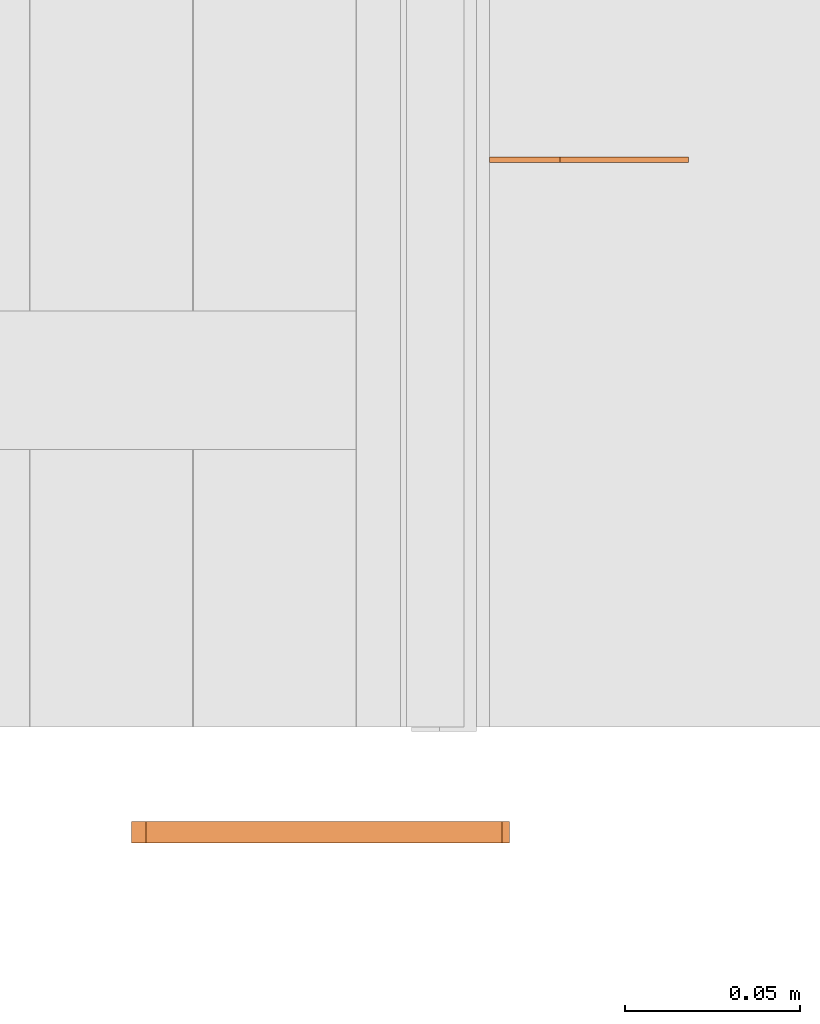
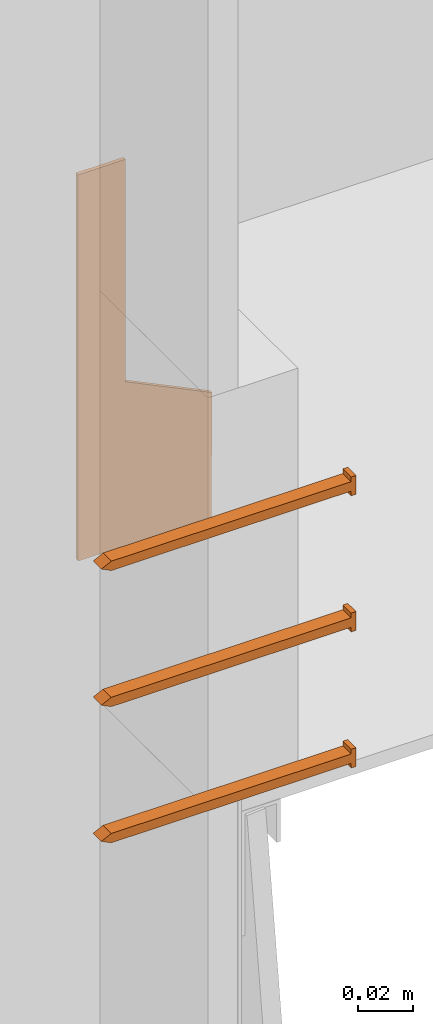
# One storey, part 12 of 22: 4 proxies.
"""IFC2X3 building model written with IfcOpenShell, lengths in feet."""

import ifcopenshell
import ifcopenshell.guid

model = None  # the IFC model being written
_history = None  # IfcOwnerHistory: only IFC2X3 demands one
_inside = {}  # id of a spatial element -> (the spatial element, [elements in it])
_under = {}  # id of a project, library or spatial element -> (it, [spatial elements below it])
_declared = {}  # id of a project -> (the project, [libraries it declares])
_typed = {}  # id of a type object -> (the type object, [elements of that type])
_made_of = {}  # id of a material, layer set ... -> (it, [elements and type objects made of it])


def new_model(schema):
    """Start an empty IFC model of exactly this schema.

    Asked for "IFC4X3", IfcOpenShell would pick the latest addendum, in which some entities
    have other attributes; the version numbers below select the first issue.
    IFC2X3 requires an IfcOwnerHistory on every rooted entity: one is made here for all.
    """
    global model, _history
    if schema == "IFC4X3":
        model = ifcopenshell.file(schema_version=(4, 3, 0, 0))
    else:
        model = ifcopenshell.file(schema=schema)
    _inside.clear()
    _under.clear()
    _declared.clear()
    _typed.clear()
    _made_of.clear()
    _history = None
    if model.schema == "IFC2X3":
        org = make("IfcOrganization", Name="unknown")
        user = make(
            "IfcPersonAndOrganization",
            ThePerson=make("IfcPerson", FamilyName="unknown"),
            TheOrganization=org,
        )
        app = make(
            "IfcApplication",
            ApplicationDeveloper=org,
            Version="unknown",
            ApplicationFullName="unknown",
            ApplicationIdentifier="unknown",
        )
        _history = make(
            "IfcOwnerHistory",
            OwningUser=user,
            OwningApplication=app,
            ChangeAction="ADDED",
            CreationDate=0,
        )
    return model


def make(cls, **values):
    """One entity of the class cls with the attributes given. An attribute that is None is left unset."""
    return model.create_entity(
        cls, **{name: value for name, value in values.items() if value is not None}
    )


def entity(cls, *values):
    """Any entity or typed value of the class cls, its attributes in the order of the schema. None: left unset."""
    e = model.create_entity(cls)
    for i, value in enumerate(values):
        if value is not None:
            e[i] = value
    return e


def rooted(cls, **values):
    """An entity with a GlobalId (a new one), such as an element, a storey or a relation."""
    return make(cls, GlobalId=ifcopenshell.guid.new(), OwnerHistory=_history, **values)


def si_unit(unit_type, name, prefix=None):
    """IfcSIUnit, for example si_unit("LENGTHUNIT", "METRE", prefix="MILLI")."""
    return make("IfcSIUnit", UnitType=unit_type, Prefix=prefix, Name=name)


def converted_unit(unit_type, name, factor, base, dimensions=None, offset=None):
    """IfcConversionBasedUnit, such as the inch: factor (a typed value) times the base unit."""
    return make(
        "IfcConversionBasedUnit"
        if offset is None
        else "IfcConversionBasedUnitWithOffset",
        ConversionOffset=offset,
        Dimensions=None
        if dimensions is None
        else entity("IfcDimensionalExponents", *dimensions),
        UnitType=unit_type,
        Name=name,
        ConversionFactor=make(
            "IfcMeasureWithUnit", ValueComponent=factor, UnitComponent=base
        ),
    )


def assignment(units):
    """IfcUnitAssignment: the units of a project."""
    return None if units is None else make("IfcUnitAssignment", Units=units)


def point(xyz):
    """IfcCartesianPoint."""
    return None if xyz is None else make("IfcCartesianPoint", Coordinates=xyz)


def direction(xyz):
    """IfcDirection."""
    return None if xyz is None else make("IfcDirection", DirectionRatios=xyz)


def frame(location, z_axis=None, x_axis=None):
    """IfcAxis2Placement3D, a coordinate frame: its origin and axes. An axis left out is left unset."""
    return make(
        "IfcAxis2Placement3D",
        Location=point(location),
        Axis=direction(z_axis),
        RefDirection=direction(x_axis),
    )


def frame_2d(location, x_axis=None):
    """IfcAxis2Placement2D, a coordinate frame in the plane: its origin and x axis."""
    return make(
        "IfcAxis2Placement2D", Location=point(location), RefDirection=direction(x_axis)
    )


def origin_with_axes():
    """The frame at (0, 0, 0) with the z axis (0, 0, 1) and the x axis (1, 0, 0) written out."""
    return frame((0.0, 0.0, 0.0), z_axis=(0.0, 0.0, 1.0), x_axis=(1.0, 0.0, 0.0))


def place(relative_to, where):
    """IfcLocalPlacement: puts the frame where relative to a parent placement (None: the world)."""
    return make(
        "IfcLocalPlacement", PlacementRelTo=relative_to, RelativePlacement=where
    )


def context(
    kind, dimensions, precision=None, world=None, true_north=None, identifier=None
):
    """IfcGeometricRepresentationContext, for example the 3D "Model" context."""
    return make(
        "IfcGeometricRepresentationContext",
        ContextIdentifier=identifier,
        ContextType=kind,
        CoordinateSpaceDimension=dimensions,
        Precision=precision,
        WorldCoordinateSystem=world,
        TrueNorth=true_north,
    )


def subcontext(parent, identifier, kind, view, scale=None):
    """IfcGeometricRepresentationSubContext, for example "Body" below "Model"."""
    return make(
        "IfcGeometricRepresentationSubContext",
        ContextIdentifier=identifier,
        ContextType=kind,
        ParentContext=parent,
        TargetScale=scale,
        TargetView=view,
    )


def project(units=None, contexts=None):
    """IfcProject with its units and contexts."""
    return rooted(
        "IfcProject",
        Name="project",
        RepresentationContexts=contexts,
        UnitsInContext=assignment(units),
    )


def spatial(cls, under=None, at=None, **own):
    """A site, building, storey or space (cls), placed at a placement, below another one or the project."""
    s = rooted(cls, ObjectPlacement=at, **own)
    if under is not None:
        _under.setdefault(under.id(), (under, []))[1].append(s)
    return s


def polyline(points):
    """IfcPolyline through the points."""
    return make("IfcPolyline", Points=[point(p) for p in points])


def outline(outer, holes=None, kind="AREA"):
    """IfcArbitraryClosedProfileDef: a profile drawn as a closed curve; with holes, ...WithVoids."""
    if holes is None:
        return make("IfcArbitraryClosedProfileDef", ProfileType=kind, OuterCurve=outer)
    return make(
        "IfcArbitraryProfileDefWithVoids",
        ProfileType=kind,
        OuterCurve=outer,
        InnerCurves=holes,
    )


def extrude(swept, where, along, depth):
    """IfcExtrudedAreaSolid: the profile swept, set in the frame where, extruded along a direction by depth."""
    return make(
        "IfcExtrudedAreaSolid",
        SweptArea=swept,
        Position=where,
        ExtrudedDirection=direction(along),
        Depth=depth,
    )


def faces_of(points, faces, orient=None, outer=None):
    """IfcFace entities. A face is a list of loops; a loop is a list of indices into points, from 0.

    orient and outer hold one flag for each loop. By default every Orientation is true, the
    first loop of a face is its IfcFaceOuterBound and the others are IfcFaceBound.
    """
    made = []
    for i, loops in enumerate(faces):
        bounds = []
        for j, loop in enumerate(loops):
            is_outer = j == 0 if outer is None else outer[i][j]
            bounds.append(
                make(
                    "IfcFaceOuterBound" if is_outer else "IfcFaceBound",
                    Bound=make("IfcPolyLoop", Polygon=[points[k] for k in loop]),
                    Orientation=True if orient is None else orient[i][j],
                )
            )
        made.append(make("IfcFace", Bounds=bounds))
    return made


def faceted_brep(points, faces, orient=None, outer=None, voids=None):
    """IfcFacetedBrep: a solid bounded by flat faces; with voids (closed shells), ...WithVoids."""
    shared = [point(p) for p in points]
    hull = make("IfcClosedShell", CfsFaces=faces_of(shared, faces, orient, outer))
    if voids is None:
        return make("IfcFacetedBrep", Outer=hull)
    return make(
        "IfcFacetedBrepWithVoids",
        Outer=hull,
        Voids=[
            make(cls, CfsFaces=faces_of(shared, fs, o, b)) for cls, fs, o, b in voids
        ],
    )


def shape(context_of_items, identifier, shape_type, items):
    """IfcShapeRepresentation: the items that make up one representation, for example the "Body"."""
    return make(
        "IfcShapeRepresentation",
        ContextOfItems=context_of_items,
        RepresentationIdentifier=identifier,
        RepresentationType=shape_type,
        Items=items,
    )


def source(mapping_origin, context_of_items, identifier, shape_type, items):
    """IfcRepresentationMap: a shape defined once, which mapped items show again and again."""
    return make(
        "IfcRepresentationMap",
        MappingOrigin=mapping_origin,
        MappedRepresentation=shape(context_of_items, identifier, shape_type, items),
    )


def transform(
    local_origin,
    x_axis=None,
    y_axis=None,
    z_axis=None,
    scale=None,
    scale2=None,
    scale3=None,
    uniform=True,
):
    """IfcCartesianTransformationOperator3D, or its non-uniform kind. x_axis, y_axis, z_axis: its Axis1, 2, 3."""
    if uniform:
        return make(
            "IfcCartesianTransformationOperator3D",
            Axis1=direction(x_axis),
            Axis2=direction(y_axis),
            LocalOrigin=point(local_origin),
            Scale=scale,
            Axis3=direction(z_axis),
        )
    return make(
        "IfcCartesianTransformationOperator3DnonUniform",
        Axis1=direction(x_axis),
        Axis2=direction(y_axis),
        LocalOrigin=point(local_origin),
        Scale=scale,
        Axis3=direction(z_axis),
        Scale2=scale2,
        Scale3=scale3,
    )


def mapped(mapping_source, mapping_target):
    """IfcMappedItem: shows the shape of a source again, moved by a transform."""
    return make(
        "IfcMappedItem", MappingSource=mapping_source, MappingTarget=mapping_target
    )


def made_of(thing, what):
    """Note that an element or type object is made of a material, layer set ...; save() writes the relation."""
    if what is not None:
        _made_of.setdefault(what.id(), (what, []))[1].append(thing)
    return thing


def type_object(cls, material=None, **own):
    """A type object (cls), such as IfcWallType, which elements share."""
    return made_of(rooted(cls, **own), material)


def type_shapes(of_type, sources):
    """Give a type object the sources (RepresentationMaps) that its elements show as mapped items."""
    of_type.RepresentationMaps = sources


def element(
    cls,
    number,
    at=None,
    inside=None,
    cuts=None,
    type_object=None,
    material=None,
    context=None,
    identifier="Body",
    shape_type=None,
    held_by="IfcProductDefinitionShape",
    body=None,
    shapes=None,
    **own,
):
    """One element of the class cls, such as IfcWall. Its Tag is "e" and its number.

    at: its placement. inside: the storey or other place that contains it. cuts: it is an
    opening in that element (IfcRelVoidsElement). A single representation is given by context,
    identifier, shape_type and body (its items); several are given by shapes. held_by: the class
    of the entity that holds the representations. save() writes the other relations.
    """
    e = rooted(cls, Tag="e%d" % number, ObjectPlacement=at, **own)
    if body is not None:
        shapes = [shape(context, identifier, shape_type, body)]
    if shapes is not None:
        e.Representation = make(held_by, Representations=shapes)
    if inside is not None:
        _inside.setdefault(inside.id(), (inside, []))[1].append(e)
    if cuts is not None:
        rooted(
            "IfcRelVoidsElement", RelatingBuildingElement=cuts, RelatedOpeningElement=e
        )
    if type_object is not None:
        _typed.setdefault(type_object.id(), (type_object, []))[1].append(e)
    return made_of(e, material)


def aggregate(whole, parts):
    """IfcRelAggregates: a whole, such as a stair, and the parts it consists of."""
    return rooted("IfcRelAggregates", RelatingObject=whole, RelatedObjects=parts)


def save(model, path):
    """Write the relations noted so far, then the file.

    IfcRelAggregates (storeys below a building ...), IfcRelContainedInSpatialStructure (elements
    in a storey), IfcRelDefinesByType, IfcRelAssociatesMaterial and IfcRelDeclares: one each for
    every whole, place, type object, material and project.
    """
    for whole, parts in _under.values():
        aggregate(whole, parts)
    for where, things in _inside.values():
        rooted(
            "IfcRelContainedInSpatialStructure",
            RelatedElements=things,
            RelatingStructure=where,
        )
    for kind, things in _typed.values():
        rooted("IfcRelDefinesByType", RelatedObjects=things, RelatingType=kind)
    for what, things in _made_of.values():
        rooted("IfcRelAssociatesMaterial", RelatedObjects=things, RelatingMaterial=what)
    for by, libraries in _declared.values():
        rooted("IfcRelDeclares", RelatingContext=by, RelatedDefinitions=libraries)
    model.write(path)


model = new_model("IFC2X3")

# Units and contexts
model_context = context("Model", 3, precision=1e-05)
plan_context = context("Plan", 2, precision=1e-05, world=frame_2d((0.0, 0.0, 0.0), x_axis=(1.0, 0.0, 0.0)))
body_context = subcontext(model_context, "Body", "Model", "MODEL_VIEW")
ifc_project = project(units=[converted_unit("VOLUMEUNIT", "cubic foot", entity("IfcReal", 0.0283168467116885), si_unit("VOLUMEUNIT", "CUBIC_METRE"), dimensions=[3, 0, 0, 0, 0, 0, 0]), converted_unit("AREAUNIT", "square foot", entity("IfcReal", 0.09290304), si_unit("AREAUNIT", "SQUARE_METRE"), dimensions=[2, 0, 0, 0, 0, 0, 0]), converted_unit("LENGTHUNIT", "foot", entity("IfcReal", 0.3048), si_unit("LENGTHUNIT", "METRE"), dimensions=[1, 0, 0, 0, 0, 0, 0])], contexts=[model_context, plan_context])

# Site, building, storey
site_placement = place(None, origin_with_axes())
site = spatial("IfcSite", under=ifc_project, at=site_placement, CompositionType="ELEMENT")
building_placement = place(site_placement, origin_with_axes())
building = spatial("IfcBuilding", under=site, at=building_placement, Name="Building", CompositionType="ELEMENT")
storey_placement = place(building_placement, origin_with_axes())
storey = spatial("IfcBuildingStorey", under=building, at=storey_placement, Name="Storey", CompositionType="ELEMENT")

# Proxies
building_element_proxy_type_1 = type_object("IfcBuildingElementProxyType", Name="Joist Hanger Type 2", PredefinedType="NOTDEFINED")
shared_shape_1 = source(origin_with_axes(), body_context, "Body", "SweptSolid", [
    extrude(outline(polyline([(-0.30774672043918, -0.0837614779358148), (0.259578570215095, -0.0837614779358148), (0.259578570215095, 0.101166234652358), (0.0772429532383683, 0.102517886815734), (0.019093234155552, -0.0180805965480725), (-0.307746744883342, -0.0180806072423934), (-0.30774672043918, -0.0837614779358148)])), frame((0.0837614901578958, 3.25657088420332e-10, -0.30774672043918), z_axis=(-2.6260885064164e-17, -1.0, -1.06301708438129e-16), x_axis=(-5.10123570052201e-08, 8.02551938471527e-17, -1.0)), (-8.20443744942168e-07, -1.67920063631755e-06, -1.0), 0.00520799982935044),
])
type_shapes(building_element_proxy_type_1, [shared_shape_1])
proxy_placement = place(storey_placement, frame((1636.09271913063, 2.41967304328608, -60.3042124450363), z_axis=(0.0, 0.0, 1.0), x_axis=(1.0, 0.0, 0.0)))
element("IfcBuildingElementProxy", 1, at=proxy_placement, inside=storey, type_object=building_element_proxy_type_1, context=body_context, shape_type="MappedRepresentation", body=[
    mapped(shared_shape_1, transform((0.0, 0.0, 0.0), x_axis=(1.0, 0.0, 0.0), y_axis=(0.0, 1.0, 0.0), z_axis=(0.0, 0.0, 1.0), scale=1.0)),
])
building_element_proxy_type_2 = type_object("IfcBuildingElementProxyType", Name="FASTENERS AT LEDGER TBD", PredefinedType="NOTDEFINED")
shared_shape_2 = source(origin_with_axes(), body_context, "Body", "Brep", [
    faceted_brep([(2.84181700394015e-09, 0.00687499949708581, -0.01999999769032), (0.333333343267441, 0.00687500182539225, -0.020000021904707), (0.333333373069763, -0.0068749962374568, -0.020000021904707), (-1.12418430120442e-09, -0.00687499856576324, -0.01999999769032), (0.347083330154419, -1.134832228189e-09, -0.020000021904707), (0.333333343267441, 0.00687500229105353, -1.9664588180035e-08), (0.347083330154419, -8.4837720182307e-10, -2.05772945349736e-08), (0.333333373069763, -0.00687499530613422, -1.9664588180035e-08), (-3.59684088069301e-10, 0.0137500017881393, 2.46167752848692e-09), (4.16939327507748e-09, 0.0068749999627471, 2.46167730644231e-09), (-1.68726022042875e-09, 0.0137500017881393, -0.01999999769032), (-0.00687499484047294, -0.0137499999254942, -0.01999999769032), (3.41041950235876e-09, -0.0137499999254942, -0.01999999769032), (4.73799532940689e-09, -0.0137499999254942, 2.46167708439771e-09), (-0.00687499297782779, -0.0137499989941716, 2.91803137209001e-09), (-0.0068749999627471, 0.0137500036507845, -0.01999999769032), (-0.00687499856576324, 0.0137500036507845, 2.91803159413462e-09), (2.03391803399455e-10, -0.00687499856576324, 2.46167752848692e-09)], [[[0, 1, 2, 3]], [[4, 1, 5, 6]], [[6, 7, 2, 4]], [[8, 9, 0, 10]], [[11, 12, 13, 14]], [[15, 11, 14, 16]], [[12, 3, 17, 13]], [[16, 8, 10, 15]], [[17, 7, 5, 9]], [[1, 4, 2]], [[12, 11, 3]], [[0, 15, 10]], [[15, 3, 11]], [[15, 0, 3]], [[7, 6, 5]], [[14, 13, 17]], [[9, 8, 16]], [[14, 17, 16]], [[17, 9, 16]], [[5, 1, 0, 9]], [[2, 7, 17, 3]]]),
])
type_shapes(building_element_proxy_type_2, [shared_shape_2])
for number, where, z_axis, x_axis in (
    (2, (1636.10423330873, 1.80255455451375, -60.579532713402), (-3.89414367418794e-07, 1.0, -1.62920684942947e-07), (-1.0, -3.89414367418794e-07, -8.74227552571938e-08)),
    (3, (1636.10423330873, 1.80255455451375, -60.3795301882927), (-3.89414424262213e-07, 1.0, 4.37113882867379e-08), (-1.0, -3.89414424262213e-07, -8.74227765734759e-08)),
    (4, (1636.10423330873, 1.80255455451375, -60.7795352385113), (-3.89414424262213e-07, 1.0, 4.37113882867379e-08), (-1.0, -3.89414424262213e-07, -8.74227765734759e-08)),
):
    element("IfcBuildingElementProxy", number, at=place(storey_placement, frame(where, z_axis=z_axis, x_axis=x_axis)), inside=storey, type_object=building_element_proxy_type_2, context=body_context, shape_type="MappedRepresentation", body=[
        mapped(shared_shape_2, transform((0.0, 0.0, 0.0), x_axis=(1.0, 0.0, 0.0), y_axis=(0.0, 1.0, 0.0), z_axis=(0.0, 0.0, 1.0), scale=1.0)),
    ])

save(model, "model.ifc")
